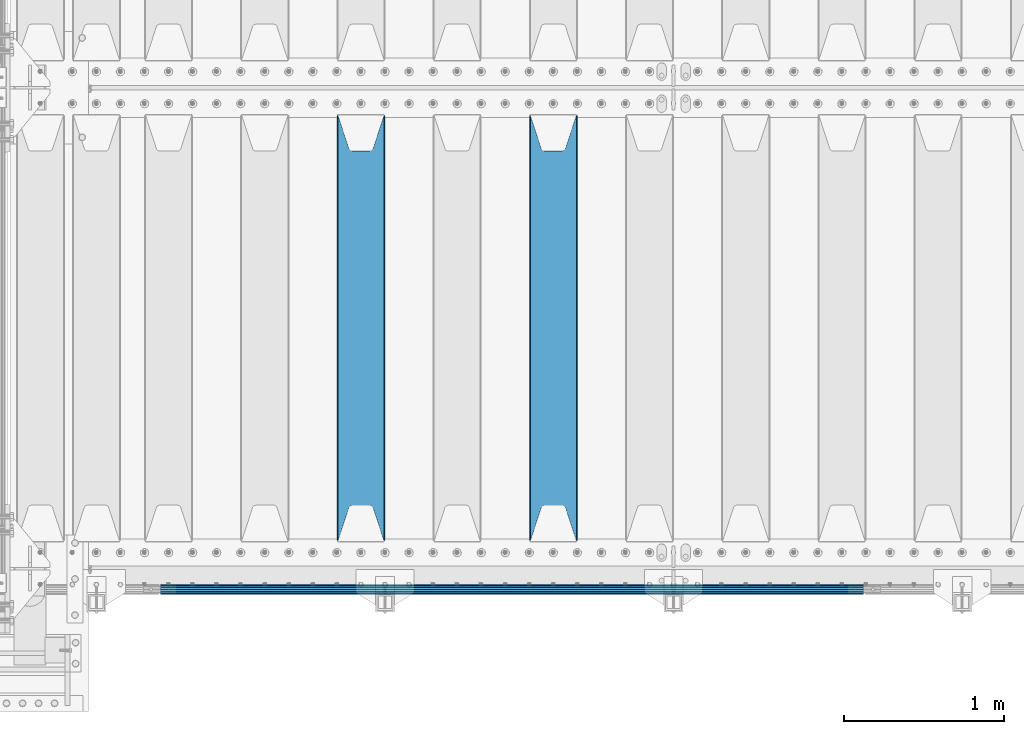
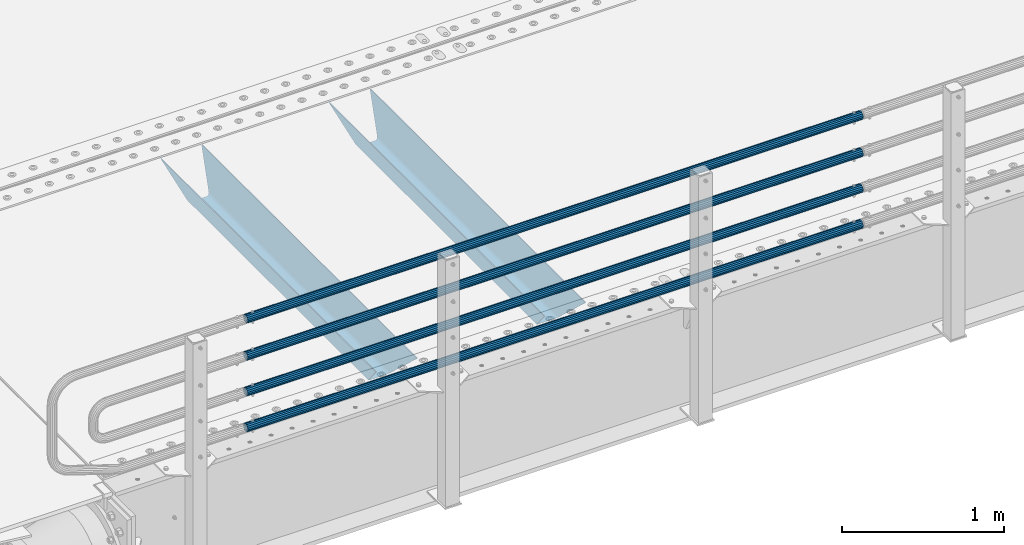
# One storey, part 100 of 240: 6 beams.
"""IFC2X3 building model written with IfcOpenShell, lengths in millimetres."""

from ifc_helpers import new_model, si_unit, frame, origin_with_axes, place, context, subcontext, project, spatial, faceted_brep, material, type_object, element, save


model = new_model("IFC2X3")

# Units and contexts
model_context = context("Model", 3, precision=1e-05, world=origin_with_axes())
body_context = subcontext(model_context, "Body", "Model", "MODEL_VIEW")
ifc_project = project(units=[si_unit("LENGTHUNIT", "METRE", prefix="MILLI"), si_unit("AREAUNIT", "SQUARE_METRE"), si_unit("VOLUMEUNIT", "CUBIC_METRE"), si_unit("MASSUNIT", "GRAM", prefix="KILO"), si_unit("TIMEUNIT", "SECOND"), si_unit("PLANEANGLEUNIT", "RADIAN"), si_unit("SOLIDANGLEUNIT", "STERADIAN"), si_unit("THERMODYNAMICTEMPERATUREUNIT", "DEGREE_CELSIUS"), si_unit("LUMINOUSINTENSITYUNIT", "LUMEN")], contexts=[model_context])

# Site, building, storey
site_placement = place(None, origin_with_axes())
site = spatial("IfcSite", under=ifc_project, at=site_placement, CompositionType="ELEMENT")
building_placement = place(site_placement, origin_with_axes())
building = spatial("IfcBuilding", under=site, at=building_placement, Name="Standard", CompositionType="ELEMENT")
storey_placement = place(building_placement, origin_with_axes())
storey = spatial("IfcBuildingStorey", under=building, at=storey_placement, Name="Undefined", CompositionType="ELEMENT", Elevation=0.0)

# Beams
ifc_material_1 = material(Name="STEEL/S355N")
beam_type_1 = type_object("IfcBeamType", PredefinedType="NOTDEFINED")
beam_1_placement = place(storey_placement, frame((45850.0, 24175.0, -115.0), z_axis=(0.0, 0.0, 1.0), x_axis=(0.0, 1.0, 0.0)))
element("IfcBeam", 1, at=beam_1_placement, inside=storey, type_object=beam_type_1, material=ifc_material_1, context=body_context, shape_type="Brep", body=[
    faceted_brep([(0.0, 150.0, 115.0), (0.0, 143.690000000002, 115.0), (2650.00000000297, 143.690000000002, 115.0), (2650.00000000297, 150.0, 115.0), (2650.00000000297, 142.059565218406, 110.000000003094), (2650.00000000297, 148.369565218403, 110.000000003094), (2441.90079219209, -80.1103600731149, -98.0992078077845), (2437.7588105432, -77.5672621345584, -102.241189456673), (2434.06523489747, -74.4080125315522, -105.934765102404), (2430.9108609509, -70.7102721255724, -109.089139048974), (2428.37322971128, -66.5649389910031, -111.626770288588), (2426.51472138055, -62.0739139532889, -113.485278619323), (2425.38102192092, -57.3475956567636, -114.618978078955), (2424.99999999987, -52.5021667386536, -115.0), (2424.99999999987, 52.5021667386536, -115.0), (2425.38102192092, 57.3475956567636, -114.618978078955), (2426.51472138055, 62.0739139532889, -113.485278619323), (2428.37322971128, 66.5649389910031, -111.626770288588), (2430.9108609509, 70.7102721255724, -109.089139048974), (2434.06523489747, 74.4080125315522, -105.934765102404), (2437.7588105432, 77.5672621345584, -102.241189456673), (2441.90079219209, 80.1103600731149, -98.0992078077846), (2446.38936140512, 81.9747917625791, -93.6106385947584), (2448.2494850041, 76.2713538057287, -91.7505149957729), (2444.62967112263, 74.76777986261, -95.3703288772456), (2441.28936334127, 72.7168944282894, -98.710636658607), (2438.31067330439, 70.1691124903809, -101.689326695487), (2435.76682334748, 67.1870637758839, -104.233176652398), (2433.72034654134, 63.8440531834931, -106.279653458539), (2432.22154950042, 60.2222587982324, -107.778450499454), (2431.30727574265, 56.4107117849126, -108.692724257221), (2430.99999999987, 52.5031078186876, -109.0), (2430.99999999987, -52.5031078186876, -109.0), (2431.30727574265, -56.4107117849126, -108.692724257221), (2432.22154950042, -60.2222587982324, -107.778450499454), (2433.72034654134, -63.8440531834931, -106.279653458539), (2435.76682334748, -67.1870637758839, -104.233176652398), (2438.31067330439, -70.1691124903809, -101.689326695487), (2441.28936334127, -72.7168944282894, -98.7106366586071), (2444.62967112263, -74.76777986261, -95.3703288772457), (2448.2494850041, -76.2713538057287, -91.7505149957729), (2650.00000000297, -142.059565218406, 110.000000003094), (2650.00000000297, -148.369565218403, 110.000000003094), (2446.38936140512, -81.9747917625791, -93.6106385947584), (2650.00000000297, -143.690000000002, 115.0), (2650.00000000297, -150.0, 115.0), (0.0, -143.690000000002, 115.0), (0.0, -150.0, 115.0), (0.0, -148.369565218258, 110.000000002667), (203.610638597427, -81.9747917625791, -93.6106385947584), (208.09920781045, -80.1103600731149, -98.0992078077845), (212.241189459342, -77.5672621345584, -102.241189456673), (215.93476510507, -74.4080125315522, -105.934765102404), (219.089139051641, -70.7102721255724, -109.089139048974), (221.626770291256, -66.5649389910031, -111.626770288588), (223.485278621989, -62.0739139532889, -113.485278619323), (224.618978081624, -57.3475956567636, -114.618978078955), (225.000000002663, -52.5021667386536, -115.0), (225.000000002663, 52.5021667386536, -115.0), (224.618978081624, 57.3475956567636, -114.618978078955), (223.485278621989, 62.0739139532889, -113.485278619323), (221.626770291256, 66.5649389910031, -111.626770288588), (219.089139051641, 70.7102721255724, -109.089139048974), (215.93476510507, 74.4080125315522, -105.934765102404), (212.241189459342, 77.5672621345584, -102.241189456673), (208.09920781045, 80.1103600731149, -98.0992078077846), (203.610638597427, 81.9747917625791, -93.6106385947584), (0.0, 148.369565218258, 110.000000002667), (0.0, 142.05956521826, 110.000000002667), (201.750514998439, 76.2713538057287, -91.7505149957729), (205.370328879908, 74.76777986261, -95.3703288772456), (208.710636661275, 72.7168944282894, -98.710636658607), (211.689326698153, 70.1691124903809, -101.689326695487), (214.233176655063, 67.1870637758839, -104.233176652398), (216.279653461206, 63.8440531834931, -106.279653458539), (217.778450502123, 60.2222587982324, -107.778450499454), (218.692724259887, 56.4107117849126, -108.692724257221), (219.000000002667, 52.5031078186876, -109.0), (219.000000002667, -52.5031078186876, -109.0), (218.692724259887, -56.4107117849126, -108.692724257221), (217.778450502123, -60.2222587982324, -107.778450499454), (216.279653461206, -63.8440531834931, -106.279653458539), (214.233176655063, -67.1870637758839, -104.233176652398), (211.689326698153, -70.1691124903809, -101.689326695487), (208.710636661275, -72.7168944282894, -98.7106366586071), (205.370328879915, -74.76777986261, -95.3703288772457), (201.750514998439, -76.2713538057287, -91.7505149957729), (0.0, -142.05956521826, 110.000000002667)], [[[0, 1, 2, 3]], [[3, 2, 4, 5]], [[6, 7, 8, 9, 10, 11, 12, 13, 14, 15, 16, 17, 18, 19, 20, 21, 22, 5, 4, 23, 24, 25, 26, 27, 28, 29, 30, 31, 32, 33, 34, 35, 36, 37, 38, 39, 40, 41, 42, 43]], [[44, 45, 42, 41]], [[46, 47, 45, 44]], [[43, 42, 45, 47, 48, 49]], [[6, 43, 49, 50]], [[7, 6, 50, 51]], [[8, 7, 51, 52]], [[9, 8, 52, 53]], [[10, 9, 53, 54]], [[11, 10, 54, 55]], [[12, 11, 55, 56]], [[13, 12, 56, 57]], [[14, 13, 57, 58]], [[15, 14, 58, 59]], [[16, 15, 59, 60]], [[17, 16, 60, 61]], [[18, 17, 61, 62]], [[19, 18, 62, 63]], [[20, 19, 63, 64]], [[21, 20, 64, 65]], [[22, 21, 65, 66]], [[0, 3, 5, 22, 66, 67]], [[1, 0, 67, 68]], [[23, 4, 2, 1, 68, 69]], [[24, 23, 69, 70]], [[25, 24, 70, 71]], [[26, 25, 71, 72]], [[27, 26, 72, 73]], [[28, 27, 73, 74]], [[29, 28, 74, 75]], [[30, 29, 75, 76]], [[31, 30, 76, 77]], [[32, 31, 77, 78]], [[33, 32, 78, 79]], [[34, 33, 79, 80]], [[35, 34, 80, 81]], [[36, 35, 81, 82]], [[37, 36, 82, 83]], [[38, 37, 83, 84]], [[39, 38, 84, 85]], [[40, 39, 85, 86]], [[46, 44, 41, 40, 86, 87]], [[47, 46, 87, 48]], [[86, 85, 84, 83, 82, 81, 80, 79, 78, 77, 76, 75, 74, 73, 72, 71, 70, 69, 68, 67, 66, 65, 64, 63, 62, 61, 60, 59, 58, 57, 56, 55, 54, 53, 52, 51, 50, 49, 48, 87]]]),
])
beam_2_placement = place(storey_placement, frame((44650.0, 24175.0, -115.0), z_axis=(0.0, 0.0, 1.0), x_axis=(0.0, 1.0, 0.0)))
element("IfcBeam", 2, at=beam_2_placement, inside=storey, type_object=beam_type_1, material=ifc_material_1, context=body_context, shape_type="Brep", body=[
    faceted_brep([(0.0, 150.0, 115.0), (0.0, 143.690000000002, 115.0), (2650.00000000297, 143.690000000002, 115.0), (2650.00000000297, 150.0, 115.0), (2650.00000000297, 142.059565218406, 110.000000003094), (2650.00000000297, 148.369565218403, 110.000000003094), (2441.90079219209, -80.1103600731149, -98.0992078077845), (2437.7588105432, -77.5672621345584, -102.241189456673), (2434.06523489747, -74.4080125315522, -105.934765102404), (2430.9108609509, -70.7102721255724, -109.089139048974), (2428.37322971128, -66.5649389910031, -111.626770288588), (2426.51472138055, -62.0739139532889, -113.485278619323), (2425.38102192092, -57.3475956567636, -114.618978078955), (2424.99999999987, -52.5021667386536, -115.0), (2424.99999999987, 52.5021667386536, -115.0), (2425.38102192092, 57.3475956567636, -114.618978078955), (2426.51472138055, 62.0739139532889, -113.485278619323), (2428.37322971128, 66.5649389910031, -111.626770288588), (2430.9108609509, 70.7102721255724, -109.089139048974), (2434.06523489747, 74.4080125315522, -105.934765102404), (2437.7588105432, 77.5672621345584, -102.241189456673), (2441.90079219209, 80.1103600731149, -98.0992078077846), (2446.38936140512, 81.9747917625791, -93.6106385947584), (2448.2494850041, 76.2713538057287, -91.7505149957729), (2444.62967112263, 74.76777986261, -95.3703288772456), (2441.28936334127, 72.7168944282894, -98.710636658607), (2438.31067330439, 70.1691124903809, -101.689326695487), (2435.76682334748, 67.1870637758839, -104.233176652398), (2433.72034654134, 63.8440531834931, -106.279653458539), (2432.22154950042, 60.2222587982324, -107.778450499454), (2431.30727574265, 56.4107117849126, -108.692724257221), (2430.99999999987, 52.5031078186876, -109.0), (2430.99999999987, -52.5031078186876, -109.0), (2431.30727574265, -56.4107117849126, -108.692724257221), (2432.22154950042, -60.2222587982324, -107.778450499454), (2433.72034654134, -63.8440531834931, -106.279653458539), (2435.76682334748, -67.1870637758839, -104.233176652398), (2438.31067330439, -70.1691124903809, -101.689326695487), (2441.28936334127, -72.7168944282894, -98.7106366586071), (2444.62967112263, -74.76777986261, -95.3703288772457), (2448.2494850041, -76.2713538057287, -91.7505149957729), (2650.00000000297, -142.059565218406, 110.000000003094), (2650.00000000297, -148.369565218403, 110.000000003094), (2446.38936140512, -81.9747917625791, -93.6106385947584), (2650.00000000297, -143.690000000002, 115.0), (2650.00000000297, -150.0, 115.0), (0.0, -143.690000000002, 115.0), (0.0, -150.0, 115.0), (0.0, -148.369565218258, 110.000000002667), (203.610638597427, -81.9747917625791, -93.6106385947584), (208.09920781045, -80.1103600731149, -98.0992078077845), (212.241189459342, -77.5672621345584, -102.241189456673), (215.93476510507, -74.4080125315522, -105.934765102404), (219.089139051641, -70.7102721255724, -109.089139048974), (221.626770291256, -66.5649389910031, -111.626770288588), (223.485278621989, -62.0739139532889, -113.485278619323), (224.618978081624, -57.3475956567636, -114.618978078955), (225.000000002663, -52.5021667386536, -115.0), (225.000000002663, 52.5021667386536, -115.0), (224.618978081624, 57.3475956567636, -114.618978078955), (223.485278621989, 62.0739139532889, -113.485278619323), (221.626770291256, 66.5649389910031, -111.626770288588), (219.089139051641, 70.7102721255724, -109.089139048974), (215.93476510507, 74.4080125315522, -105.934765102404), (212.241189459342, 77.5672621345584, -102.241189456673), (208.09920781045, 80.1103600731149, -98.0992078077846), (203.610638597427, 81.9747917625791, -93.6106385947584), (0.0, 148.369565218258, 110.000000002667), (0.0, 142.05956521826, 110.000000002667), (201.750514998439, 76.2713538057287, -91.7505149957729), (205.370328879908, 74.76777986261, -95.3703288772456), (208.710636661275, 72.7168944282894, -98.710636658607), (211.689326698153, 70.1691124903809, -101.689326695487), (214.233176655063, 67.1870637758839, -104.233176652398), (216.279653461206, 63.8440531834931, -106.279653458539), (217.778450502123, 60.2222587982324, -107.778450499454), (218.692724259887, 56.4107117849126, -108.692724257221), (219.000000002667, 52.5031078186876, -109.0), (219.000000002667, -52.5031078186876, -109.0), (218.692724259887, -56.4107117849126, -108.692724257221), (217.778450502123, -60.2222587982324, -107.778450499454), (216.279653461206, -63.8440531834931, -106.279653458539), (214.233176655063, -67.1870637758839, -104.233176652398), (211.689326698153, -70.1691124903809, -101.689326695487), (208.710636661275, -72.7168944282894, -98.7106366586071), (205.370328879915, -74.76777986261, -95.3703288772457), (201.750514998439, -76.2713538057287, -91.7505149957729), (0.0, -142.05956521826, 110.000000002667)], [[[0, 1, 2, 3]], [[3, 2, 4, 5]], [[6, 7, 8, 9, 10, 11, 12, 13, 14, 15, 16, 17, 18, 19, 20, 21, 22, 5, 4, 23, 24, 25, 26, 27, 28, 29, 30, 31, 32, 33, 34, 35, 36, 37, 38, 39, 40, 41, 42, 43]], [[44, 45, 42, 41]], [[46, 47, 45, 44]], [[43, 42, 45, 47, 48, 49]], [[6, 43, 49, 50]], [[7, 6, 50, 51]], [[8, 7, 51, 52]], [[9, 8, 52, 53]], [[10, 9, 53, 54]], [[11, 10, 54, 55]], [[12, 11, 55, 56]], [[13, 12, 56, 57]], [[14, 13, 57, 58]], [[15, 14, 58, 59]], [[16, 15, 59, 60]], [[17, 16, 60, 61]], [[18, 17, 61, 62]], [[19, 18, 62, 63]], [[20, 19, 63, 64]], [[21, 20, 64, 65]], [[22, 21, 65, 66]], [[0, 3, 5, 22, 66, 67]], [[1, 0, 67, 68]], [[23, 4, 2, 1, 68, 69]], [[24, 23, 69, 70]], [[25, 24, 70, 71]], [[26, 25, 71, 72]], [[27, 26, 72, 73]], [[28, 27, 73, 74]], [[29, 28, 74, 75]], [[30, 29, 75, 76]], [[31, 30, 76, 77]], [[32, 31, 77, 78]], [[33, 32, 78, 79]], [[34, 33, 79, 80]], [[35, 34, 80, 81]], [[36, 35, 81, 82]], [[37, 36, 82, 83]], [[38, 37, 83, 84]], [[39, 38, 84, 85]], [[40, 39, 85, 86]], [[46, 44, 41, 40, 86, 87]], [[47, 46, 87, 48]], [[86, 85, 84, 83, 82, 81, 80, 79, 78, 77, 76, 75, 74, 73, 72, 71, 70, 69, 68, 67, 66, 65, 64, 63, 62, 61, 60, 59, 58, 57, 56, 55, 54, 53, 52, 51, 50, 49, 48, 87]]]),
])
ifc_material_2 = material()
beam_type_2 = type_object("IfcBeamType", PredefinedType="NOTDEFINED")
beam_3_placement = place(storey_placement, frame((47783.9999999999, 23870.1500000001, 149.849999999748), z_axis=(0.0, 0.0, -1.0), x_axis=(-1.0, 0.0, 0.0)))
element("IfcBeam", 3, at=beam_3_placement, inside=storey, type_object=beam_type_2, material=ifc_material_2, context=body_context, shape_type="Brep", body=[
    faceted_brep([(0.0, -26.5500000000029, 0.0), (0.0, -24.5290015881765, 10.1602451292931), (4384.00249699992, -24.5290015881765, 10.1602451292931), (4384.00249699992, -26.5500000000029, 0.0), (0.0, -18.7736850405054, 18.7736850405028), (4384.00249699992, -18.7736850405054, 18.7736850405028), (0.0, -10.1602451292929, 24.5290015881747), (4384.00249699992, -10.1602451292929, 24.5290015881747), (0.0, 0.0, 26.55), (4384.00249699992, 0.0, 26.55), (0.0, 10.1602451292929, 24.5290015881747), (4384.00249699992, 10.1602451292929, 24.5290015881747), (0.0, 18.7736850405054, 18.7736850405028), (4384.00249699992, 18.7736850405054, 18.7736850405028), (0.0, 24.5290015881765, 10.1602451292931), (4384.00249699992, 24.5290015881765, 10.1602451292931), (0.0, 26.5500000000029, 0.0), (4384.00249699992, 26.5500000000029, 0.0), (0.0, 24.5290015881765, -10.1602451292931), (4384.00249699992, 24.5290015881765, -10.1602451292931), (0.0, 18.7736850405054, -18.7736850405028), (4384.00249699992, 18.7736850405054, -18.7736850405028), (0.0, 10.1602451292929, -24.5290015881747), (4384.00249699992, 10.1602451292929, -24.5290015881747), (0.0, 0.0, -26.55), (4384.00249699992, 0.0, -26.55), (0.0, -10.1602451292929, -24.5290015881747), (4384.00249699992, -10.1602451292929, -24.5290015881747), (0.0, -18.7736850405054, -18.7736850405028), (4384.00249699992, -18.7736850405054, -18.7736850405028), (0.0, -24.5290015881765, -10.1602451292931), (4384.00249699992, -24.5290015881765, -10.1602451292931), (0.0, -30.1500000000015, 0.0), (0.0, -27.8549679052157, -11.5379054858058), (4384.00249699992, -27.8549679052157, -11.5379054858075), (4384.00249699992, -30.1500000000015, 0.0), (0.0, -21.3192694527752, -21.3192694527752), (4384.00249699992, -21.3192694527752, -21.3192694527744), (0.0, -11.5379054858058, -27.8549679052157), (4384.00249699992, -11.5379054858058, -27.8549679052153), (0.0, 0.0, -30.1500000000015), (4384.00249699992, 0.0, -30.15), (0.0, 11.5379054858058, -27.8549679052157), (4384.00249699992, 11.5379054858058, -27.8549679052153), (0.0, 21.3192694527752, -21.3192694527752), (4384.00249699992, 21.3192694527752, -21.3192694527744), (0.0, 27.8549679052157, -11.5379054858058), (4384.00249699992, 27.8549679052157, -11.5379054858074), (0.0, 30.1500000000015, 0.0), (4384.00249699992, 30.1500000000015, 0.0), (0.0, 27.8549679052157, 11.5379054858058), (4384.00249699992, 27.8549679052157, 11.5379054858075), (0.0, 21.3192694527752, 21.3192694527752), (4384.00249699992, 21.3192694527752, 21.3192694527744), (0.0, 11.5379054858058, 27.8549679052157), (4384.00249699992, 11.5379054858058, 27.8549679052153), (0.0, 0.0, 30.1500000000015), (4384.00249699992, 0.0, 30.15), (0.0, -11.5379054858058, 27.8549679052157), (4384.00249699992, -11.5379054858058, 27.8549679052153), (0.0, -21.3192694527752, 21.3192694527752), (4384.00249699992, -21.3192694527752, 21.3192694527744), (0.0, -27.8549679052157, 11.5379054858058), (4384.00249699992, -27.8549679052157, 11.5379054858075)], [[[0, 1, 2, 3]], [[1, 4, 5, 2]], [[4, 6, 7, 5]], [[6, 8, 9, 7]], [[8, 10, 11, 9]], [[10, 12, 13, 11]], [[12, 14, 15, 13]], [[14, 16, 17, 15]], [[16, 18, 19, 17]], [[18, 20, 21, 19]], [[20, 22, 23, 21]], [[22, 24, 25, 23]], [[24, 26, 27, 25]], [[26, 28, 29, 27]], [[28, 30, 31, 29]], [[30, 0, 3, 31]], [[32, 33, 34, 35]], [[33, 36, 37, 34]], [[36, 38, 39, 37]], [[38, 40, 41, 39]], [[40, 42, 43, 41]], [[42, 44, 45, 43]], [[44, 46, 47, 45]], [[46, 48, 49, 47]], [[48, 50, 51, 49]], [[50, 52, 53, 51]], [[52, 54, 55, 53]], [[54, 56, 57, 55]], [[56, 58, 59, 57]], [[58, 60, 61, 59]], [[60, 62, 63, 61]], [[62, 32, 35, 63]], [[37, 39, 41, 43, 45, 47, 49, 51, 53, 55, 57, 59, 61, 63, 35, 34], [5, 7, 9, 11, 13, 15, 17, 19, 21, 23, 25, 27, 29, 31, 3, 2]], [[62, 60, 58, 56, 54, 52, 50, 48, 46, 44, 42, 40, 38, 36, 33, 32], [30, 28, 26, 24, 22, 20, 18, 16, 14, 12, 10, 8, 6, 4, 1, 0]]]),
])
beam_4_placement = place(storey_placement, frame((47783.9999999999, 23870.1500000001, 420.149999999748), z_axis=(0.0, 0.0, -1.0), x_axis=(-1.0, 0.0, 0.0)))
element("IfcBeam", 4, at=beam_4_placement, inside=storey, type_object=beam_type_2, material=ifc_material_2, context=body_context, shape_type="Brep", body=[
    faceted_brep([(0.0, -26.5500000000029, 0.0), (0.0, -24.5290015881765, 10.1602451292931), (4384.00249699992, -24.5290015881765, 10.1602451292931), (4384.00249699992, -26.5500000000029, 0.0), (0.0, -18.7736850405054, 18.7736850405028), (4384.00249699992, -18.7736850405054, 18.7736850405028), (0.0, -10.1602451292929, 24.5290015881747), (4384.00249699992, -10.1602451292929, 24.5290015881747), (0.0, 0.0, 26.55), (4384.00249699992, 0.0, 26.55), (0.0, 10.1602451292929, 24.5290015881747), (4384.00249699992, 10.1602451292929, 24.5290015881747), (0.0, 18.7736850405054, 18.7736850405028), (4384.00249699992, 18.7736850405054, 18.7736850405028), (0.0, 24.5290015881765, 10.1602451292931), (4384.00249699992, 24.5290015881765, 10.1602451292931), (0.0, 26.5500000000029, 0.0), (4384.00249699992, 26.5500000000029, 0.0), (0.0, 24.5290015881765, -10.1602451292931), (4384.00249699992, 24.5290015881765, -10.1602451292931), (0.0, 18.7736850405054, -18.7736850405028), (4384.00249699992, 18.7736850405054, -18.7736850405028), (0.0, 10.1602451292929, -24.5290015881747), (4384.00249699992, 10.1602451292929, -24.5290015881747), (0.0, 0.0, -26.55), (4384.00249699992, 0.0, -26.55), (0.0, -10.1602451292929, -24.5290015881747), (4384.00249699992, -10.1602451292929, -24.5290015881747), (0.0, -18.7736850405054, -18.7736850405028), (4384.00249699992, -18.7736850405054, -18.7736850405028), (0.0, -24.5290015881765, -10.1602451292931), (4384.00249699992, -24.5290015881765, -10.1602451292931), (0.0, -30.1500000000015, 0.0), (0.0, -27.8549679052157, -11.5379054858058), (4384.00249699992, -27.8549679052157, -11.5379054858075), (4384.00249699992, -30.1500000000015, 0.0), (0.0, -21.3192694527752, -21.3192694527752), (4384.00249699992, -21.3192694527752, -21.3192694527744), (0.0, -11.5379054858058, -27.8549679052157), (4384.00249699992, -11.5379054858058, -27.8549679052153), (0.0, 0.0, -30.1500000000015), (4384.00249699992, 0.0, -30.15), (0.0, 11.5379054858058, -27.8549679052157), (4384.00249699992, 11.5379054858058, -27.8549679052153), (0.0, 21.3192694527752, -21.3192694527752), (4384.00249699992, 21.3192694527752, -21.3192694527744), (0.0, 27.8549679052157, -11.5379054858058), (4384.00249699992, 27.8549679052157, -11.5379054858074), (0.0, 30.1500000000015, 0.0), (4384.00249699992, 30.1500000000015, 0.0), (0.0, 27.8549679052157, 11.5379054858058), (4384.00249699992, 27.8549679052157, 11.5379054858075), (0.0, 21.3192694527752, 21.3192694527752), (4384.00249699992, 21.3192694527752, 21.3192694527744), (0.0, 11.5379054858058, 27.8549679052157), (4384.00249699992, 11.5379054858058, 27.8549679052153), (0.0, 0.0, 30.1500000000015), (4384.00249699992, 0.0, 30.15), (0.0, -11.5379054858058, 27.8549679052157), (4384.00249699992, -11.5379054858058, 27.8549679052153), (0.0, -21.3192694527752, 21.3192694527752), (4384.00249699992, -21.3192694527752, 21.3192694527744), (0.0, -27.8549679052157, 11.5379054858058), (4384.00249699992, -27.8549679052157, 11.5379054858075)], [[[0, 1, 2, 3]], [[1, 4, 5, 2]], [[4, 6, 7, 5]], [[6, 8, 9, 7]], [[8, 10, 11, 9]], [[10, 12, 13, 11]], [[12, 14, 15, 13]], [[14, 16, 17, 15]], [[16, 18, 19, 17]], [[18, 20, 21, 19]], [[20, 22, 23, 21]], [[22, 24, 25, 23]], [[24, 26, 27, 25]], [[26, 28, 29, 27]], [[28, 30, 31, 29]], [[30, 0, 3, 31]], [[32, 33, 34, 35]], [[33, 36, 37, 34]], [[36, 38, 39, 37]], [[38, 40, 41, 39]], [[40, 42, 43, 41]], [[42, 44, 45, 43]], [[44, 46, 47, 45]], [[46, 48, 49, 47]], [[48, 50, 51, 49]], [[50, 52, 53, 51]], [[52, 54, 55, 53]], [[54, 56, 57, 55]], [[56, 58, 59, 57]], [[58, 60, 61, 59]], [[60, 62, 63, 61]], [[62, 32, 35, 63]], [[37, 39, 41, 43, 45, 47, 49, 51, 53, 55, 57, 59, 61, 63, 35, 34], [5, 7, 9, 11, 13, 15, 17, 19, 21, 23, 25, 27, 29, 31, 3, 2]], [[62, 60, 58, 56, 54, 52, 50, 48, 46, 44, 42, 40, 38, 36, 33, 32], [30, 28, 26, 24, 22, 20, 18, 16, 14, 12, 10, 8, 6, 4, 1, 0]]]),
])
beam_5_placement = place(storey_placement, frame((47783.9999999999, 23870.1500000001, 969.849999999748), z_axis=(0.0, 0.0, -1.0), x_axis=(-1.0, 0.0, 0.0)))
element("IfcBeam", 5, at=beam_5_placement, inside=storey, type_object=beam_type_2, material=ifc_material_2, context=body_context, shape_type="Brep", body=[
    faceted_brep([(0.0, -26.5500000000029, 0.0), (0.0, -24.5290015881765, 10.1602451292931), (4384.00249699992, -24.5290015881765, 10.1602451292931), (4384.00249699992, -26.5500000000029, 0.0), (0.0, -18.7736850405054, 18.7736850405028), (4384.00249699992, -18.7736850405054, 18.7736850405028), (0.0, -10.1602451292929, 24.5290015881747), (4384.00249699992, -10.1602451292929, 24.5290015881747), (0.0, 0.0, 26.55), (4384.00249699992, 0.0, 26.55), (0.0, 10.1602451292929, 24.5290015881747), (4384.00249699992, 10.1602451292929, 24.5290015881747), (0.0, 18.7736850405054, 18.7736850405028), (4384.00249699992, 18.7736850405054, 18.7736850405028), (0.0, 24.5290015881765, 10.1602451292931), (4384.00249699992, 24.5290015881765, 10.1602451292931), (0.0, 26.5500000000029, 0.0), (4384.00249699992, 26.5500000000029, 0.0), (0.0, 24.5290015881765, -10.1602451292931), (4384.00249699992, 24.5290015881765, -10.1602451292931), (0.0, 18.7736850405054, -18.7736850405028), (4384.00249699992, 18.7736850405054, -18.7736850405028), (0.0, 10.1602451292929, -24.5290015881747), (4384.00249699992, 10.1602451292929, -24.5290015881747), (0.0, 0.0, -26.55), (4384.00249699992, 0.0, -26.55), (0.0, -10.1602451292929, -24.5290015881747), (4384.00249699992, -10.1602451292929, -24.5290015881747), (0.0, -18.7736850405054, -18.7736850405028), (4384.00249699992, -18.7736850405054, -18.7736850405028), (0.0, -24.5290015881765, -10.1602451292931), (4384.00249699992, -24.5290015881765, -10.1602451292931), (0.0, -30.1500000000015, 0.0), (0.0, -27.8549679052157, -11.5379054858058), (4384.00249699992, -27.8549679052157, -11.5379054858075), (4384.00249699992, -30.1500000000015, 0.0), (0.0, -21.3192694527752, -21.3192694527752), (4384.00249699992, -21.3192694527752, -21.3192694527744), (0.0, -11.5379054858058, -27.8549679052157), (4384.00249699992, -11.5379054858058, -27.8549679052153), (0.0, 0.0, -30.1500000000015), (4384.00249699992, 0.0, -30.15), (0.0, 11.5379054858058, -27.8549679052157), (4384.00249699992, 11.5379054858058, -27.8549679052153), (0.0, 21.3192694527752, -21.3192694527752), (4384.00249699992, 21.3192694527752, -21.3192694527744), (0.0, 27.8549679052157, -11.5379054858058), (4384.00249699992, 27.8549679052157, -11.5379054858074), (0.0, 30.1500000000015, 0.0), (4384.00249699992, 30.1500000000015, 0.0), (0.0, 27.8549679052157, 11.5379054858058), (4384.00249699992, 27.8549679052157, 11.5379054858075), (0.0, 21.3192694527752, 21.3192694527752), (4384.00249699992, 21.3192694527752, 21.3192694527744), (0.0, 11.5379054858058, 27.8549679052157), (4384.00249699992, 11.5379054858058, 27.8549679052153), (0.0, 0.0, 30.1500000000015), (4384.00249699992, 0.0, 30.15), (0.0, -11.5379054858058, 27.8549679052157), (4384.00249699992, -11.5379054858058, 27.8549679052153), (0.0, -21.3192694527752, 21.3192694527752), (4384.00249699992, -21.3192694527752, 21.3192694527744), (0.0, -27.8549679052157, 11.5379054858058), (4384.00249699992, -27.8549679052157, 11.5379054858075)], [[[0, 1, 2, 3]], [[1, 4, 5, 2]], [[4, 6, 7, 5]], [[6, 8, 9, 7]], [[8, 10, 11, 9]], [[10, 12, 13, 11]], [[12, 14, 15, 13]], [[14, 16, 17, 15]], [[16, 18, 19, 17]], [[18, 20, 21, 19]], [[20, 22, 23, 21]], [[22, 24, 25, 23]], [[24, 26, 27, 25]], [[26, 28, 29, 27]], [[28, 30, 31, 29]], [[30, 0, 3, 31]], [[32, 33, 34, 35]], [[33, 36, 37, 34]], [[36, 38, 39, 37]], [[38, 40, 41, 39]], [[40, 42, 43, 41]], [[42, 44, 45, 43]], [[44, 46, 47, 45]], [[46, 48, 49, 47]], [[48, 50, 51, 49]], [[50, 52, 53, 51]], [[52, 54, 55, 53]], [[54, 56, 57, 55]], [[56, 58, 59, 57]], [[58, 60, 61, 59]], [[60, 62, 63, 61]], [[62, 32, 35, 63]], [[37, 39, 41, 43, 45, 47, 49, 51, 53, 55, 57, 59, 61, 63, 35, 34], [5, 7, 9, 11, 13, 15, 17, 19, 21, 23, 25, 27, 29, 31, 3, 2]], [[62, 60, 58, 56, 54, 52, 50, 48, 46, 44, 42, 40, 38, 36, 33, 32], [30, 28, 26, 24, 22, 20, 18, 16, 14, 12, 10, 8, 6, 4, 1, 0]]]),
])
beam_6_placement = place(storey_placement, frame((47783.9999999999, 23870.1500000001, 689.849999999748), z_axis=(0.0, 0.0, -1.0), x_axis=(-1.0, 0.0, 0.0)))
element("IfcBeam", 6, at=beam_6_placement, inside=storey, type_object=beam_type_2, material=ifc_material_2, context=body_context, shape_type="Brep", body=[
    faceted_brep([(0.0, -26.5500000000029, 0.0), (0.0, -24.5290015881765, 10.1602451292931), (4384.00249699992, -24.5290015881765, 10.1602451292931), (4384.00249699992, -26.5500000000029, 0.0), (0.0, -18.7736850405054, 18.7736850405028), (4384.00249699992, -18.7736850405054, 18.7736850405028), (0.0, -10.1602451292929, 24.5290015881747), (4384.00249699992, -10.1602451292929, 24.5290015881747), (0.0, 0.0, 26.55), (4384.00249699992, 0.0, 26.55), (0.0, 10.1602451292929, 24.5290015881747), (4384.00249699992, 10.1602451292929, 24.5290015881747), (0.0, 18.7736850405054, 18.7736850405028), (4384.00249699992, 18.7736850405054, 18.7736850405028), (0.0, 24.5290015881765, 10.1602451292931), (4384.00249699992, 24.5290015881765, 10.1602451292931), (0.0, 26.5500000000029, 0.0), (4384.00249699992, 26.5500000000029, 0.0), (0.0, 24.5290015881765, -10.1602451292931), (4384.00249699992, 24.5290015881765, -10.1602451292931), (0.0, 18.7736850405054, -18.7736850405028), (4384.00249699992, 18.7736850405054, -18.7736850405028), (0.0, 10.1602451292929, -24.5290015881747), (4384.00249699992, 10.1602451292929, -24.5290015881747), (0.0, 0.0, -26.55), (4384.00249699992, 0.0, -26.55), (0.0, -10.1602451292929, -24.5290015881747), (4384.00249699992, -10.1602451292929, -24.5290015881747), (0.0, -18.7736850405054, -18.7736850405028), (4384.00249699992, -18.7736850405054, -18.7736850405028), (0.0, -24.5290015881765, -10.1602451292931), (4384.00249699992, -24.5290015881765, -10.1602451292931), (0.0, -30.1500000000015, 0.0), (0.0, -27.8549679052157, -11.5379054858058), (4384.00249699992, -27.8549679052157, -11.5379054858075), (4384.00249699992, -30.1500000000015, 0.0), (0.0, -21.3192694527752, -21.3192694527752), (4384.00249699992, -21.3192694527752, -21.3192694527744), (0.0, -11.5379054858058, -27.8549679052157), (4384.00249699992, -11.5379054858058, -27.8549679052153), (0.0, 0.0, -30.1500000000015), (4384.00249699992, 0.0, -30.15), (0.0, 11.5379054858058, -27.8549679052157), (4384.00249699992, 11.5379054858058, -27.8549679052153), (0.0, 21.3192694527752, -21.3192694527752), (4384.00249699992, 21.3192694527752, -21.3192694527744), (0.0, 27.8549679052157, -11.5379054858058), (4384.00249699992, 27.8549679052157, -11.5379054858074), (0.0, 30.1500000000015, 0.0), (4384.00249699992, 30.1500000000015, 0.0), (0.0, 27.8549679052157, 11.5379054858058), (4384.00249699992, 27.8549679052157, 11.5379054858075), (0.0, 21.3192694527752, 21.3192694527752), (4384.00249699992, 21.3192694527752, 21.3192694527744), (0.0, 11.5379054858058, 27.8549679052157), (4384.00249699992, 11.5379054858058, 27.8549679052153), (0.0, 0.0, 30.1500000000015), (4384.00249699992, 0.0, 30.15), (0.0, -11.5379054858058, 27.8549679052157), (4384.00249699992, -11.5379054858058, 27.8549679052153), (0.0, -21.3192694527752, 21.3192694527752), (4384.00249699992, -21.3192694527752, 21.3192694527744), (0.0, -27.8549679052157, 11.5379054858058), (4384.00249699992, -27.8549679052157, 11.5379054858075)], [[[0, 1, 2, 3]], [[1, 4, 5, 2]], [[4, 6, 7, 5]], [[6, 8, 9, 7]], [[8, 10, 11, 9]], [[10, 12, 13, 11]], [[12, 14, 15, 13]], [[14, 16, 17, 15]], [[16, 18, 19, 17]], [[18, 20, 21, 19]], [[20, 22, 23, 21]], [[22, 24, 25, 23]], [[24, 26, 27, 25]], [[26, 28, 29, 27]], [[28, 30, 31, 29]], [[30, 0, 3, 31]], [[32, 33, 34, 35]], [[33, 36, 37, 34]], [[36, 38, 39, 37]], [[38, 40, 41, 39]], [[40, 42, 43, 41]], [[42, 44, 45, 43]], [[44, 46, 47, 45]], [[46, 48, 49, 47]], [[48, 50, 51, 49]], [[50, 52, 53, 51]], [[52, 54, 55, 53]], [[54, 56, 57, 55]], [[56, 58, 59, 57]], [[58, 60, 61, 59]], [[60, 62, 63, 61]], [[62, 32, 35, 63]], [[37, 39, 41, 43, 45, 47, 49, 51, 53, 55, 57, 59, 61, 63, 35, 34], [5, 7, 9, 11, 13, 15, 17, 19, 21, 23, 25, 27, 29, 31, 3, 2]], [[62, 60, 58, 56, 54, 52, 50, 48, 46, 44, 42, 40, 38, 36, 33, 32], [30, 28, 26, 24, 22, 20, 18, 16, 14, 12, 10, 8, 6, 4, 1, 0]]]),
])

save(model, "model.ifc")
